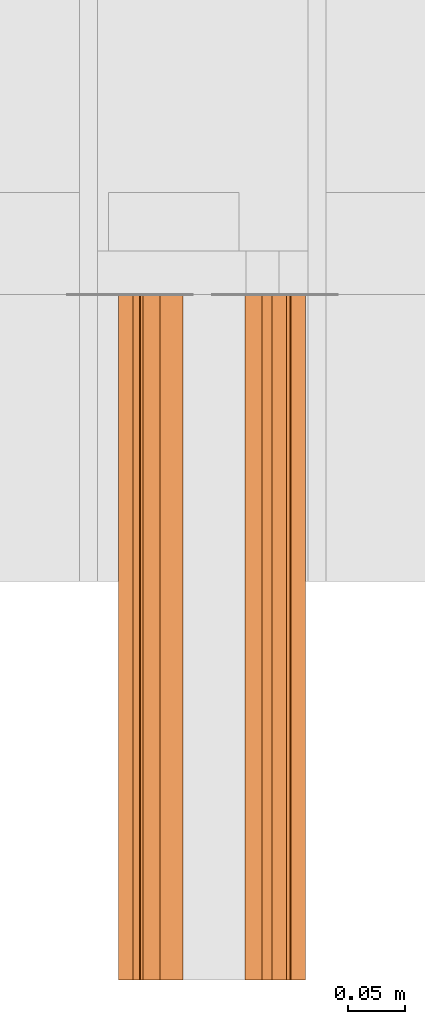
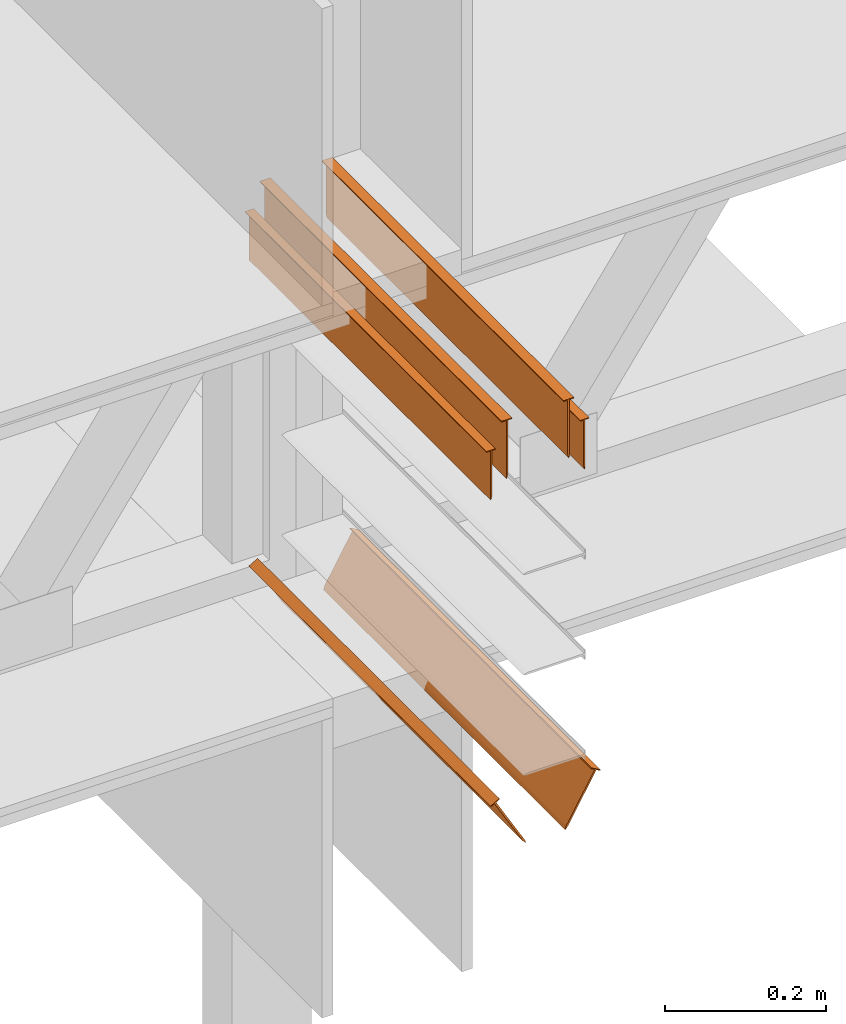
# One storey, part 2 of 2: 4 proxies.
"""IFC2X3 building model written with IfcOpenShell, lengths in metres."""

from ifc_helpers import new_model, si_unit, frame, frame_2d, origin_with_axes, place, context, subcontext, project, spatial, faceted_brep, element, save


model = new_model("IFC2X3")

# Units and contexts
model_context = context("Model", 3, precision=1e-05, world=origin_with_axes())
plan_context = context("Plan", 2, precision=1e-05, world=frame_2d((0.0, 0.0, 0.0), x_axis=(1.0, 0.0, 0.0)))
body_context = subcontext(model_context, "Body", "Model", "MODEL_VIEW")
ifc_project = project(units=[si_unit("AREAUNIT", "SQUARE_METRE"), si_unit("VOLUMEUNIT", "CUBIC_METRE"), si_unit("LENGTHUNIT", "METRE")], contexts=[model_context, plan_context])

# Site, building, storey
site_placement = place(None, origin_with_axes())
site = spatial("IfcSite", under=ifc_project, at=site_placement, CompositionType="ELEMENT")
building_placement = place(site_placement, origin_with_axes())
building = spatial("IfcBuilding", under=site, at=building_placement, Name="Building", CompositionType="ELEMENT")
storey_placement = place(building_placement, origin_with_axes())
storey = spatial("IfcBuildingStorey", under=building, at=storey_placement, Name="Storey", CompositionType="ELEMENT")

# Proxies
proxy_1_placement = place(storey_placement, frame((1.90271139144897, -0.162212371826172, 1.34063541889191), z_axis=(0.0, 0.0, 1.0), x_axis=(-1.62920684942947e-07, 1.0, 0.0)))
element("IfcBuildingElementProxy", 1, at=proxy_1_placement, inside=storey, Name="Generic Models 856:Generic Models 1:245", context=body_context, shape_type="Brep", body=[
    faceted_brep([(0.600274682044983, -0.00680737011134624, 0.00236264755949378), (0.600274682044983, -0.00744043942540884, 0.0), (0.0, -0.00744043942540884, 0.0), (0.0, -0.00680737011134624, 0.00236264755949378), (0.600274682044983, -0.0890476405620575, 0.0897103920578957), (0.600274682044983, -0.0890476405620575, 0.0883321240544319), (0.0, -0.0890476405620575, 0.0883321240544319), (0.0, -0.0890476405620575, 0.0897103920578957), (0.600274682044983, -0.00936781149357557, 0.00719304941594601), (0.600274682044983, -0.00936781149357557, 0.0883321240544319), (0.600274682044983, -0.0148808788508177, 0.0897103920578957), (0.600274682044983, -0.0148808788508177, 0.0883321240544319), (0.600274682044983, -0.00680737011134624, 0.0883321240544319), (0.600274682044983, 0.0, 0.0897103920578957), (0.600274682044983, 0.0, 0.0883321240544319), (0.0, 0.0, 0.0883321240544319), (0.0, 0.0, 0.0897103920578957), (0.600274682044983, -0.0945607125759125, 0.00719304941594601), (0.600274682044983, -0.0971211642026901, 0.00236264755949378), (0.600274682044983, -0.0964880883693695, 0.0), (0.600274682044983, -0.0971211642026901, 0.0883321240544319), (0.600274682044983, -0.103928528726101, 0.0897103920578957), (0.600274682044983, -0.103928528726101, 0.0883321240544319), (0.600274682044983, -0.0945607125759125, 0.0883321240544319), (0.0, -0.0148808788508177, 0.0883321240544319), (0.0, -0.00936781149357557, 0.0883321240544319), (0.0, -0.0945607125759125, 0.0883321240544319), (0.0, -0.0971211642026901, 0.0883321240544319), (0.0, -0.103928528726101, 0.0897103920578957), (0.0, -0.103928528726101, 0.0883321240544319), (0.0, -0.0945607125759125, 0.00719304941594601), (0.0, -0.0964880883693695, 0.0), (0.0, -0.0971211642026901, 0.00236264755949378), (0.0, -0.00680737011134624, 0.0883321240544319), (0.0, -0.0148808788508177, 0.0897103920578957), (0.0, -0.00936781149357557, 0.00719304941594601)], [[[0, 1, 2, 3]], [[4, 5, 6, 7]], [[8, 1, 0]], [[9, 10, 11]], [[12, 9, 8]], [[12, 10, 9]], [[13, 12, 14]], [[13, 10, 12]], [[0, 12, 8]], [[13, 14, 15, 16]], [[17, 18, 19]], [[20, 21, 22]], [[23, 20, 17]], [[4, 23, 5]], [[4, 21, 20]], [[4, 20, 23]], [[20, 18, 17]], [[9, 11, 24, 25]], [[26, 7, 6]], [[27, 7, 26]], [[28, 7, 27]], [[29, 28, 27]], [[30, 27, 26]], [[31, 32, 30]], [[32, 27, 30]], [[19, 18, 32, 31]], [[22, 29, 27, 20]], [[14, 12, 33, 15]], [[21, 4, 7, 28]], [[22, 21, 28, 29]], [[34, 10, 13, 16]], [[5, 23, 26, 6]], [[27, 32, 18, 20]], [[33, 16, 15]], [[34, 16, 33]], [[34, 33, 25]], [[24, 34, 25]], [[35, 25, 33]], [[2, 35, 3]], [[33, 3, 35]], [[8, 9, 25, 35]], [[12, 0, 3, 33]], [[23, 17, 30, 26]], [[1, 8, 35, 2]], [[17, 19, 31, 30]], [[11, 10, 34, 24]]]),
])
proxy_2_placement = place(storey_placement, frame((1.88110494613647, -0.162212371826172, 1.31583797931671), z_axis=(0.0, 0.0, 1.0), x_axis=(-1.62920684942947e-07, 1.0, 0.0)))
element("IfcBuildingElementProxy", 2, at=proxy_2_placement, inside=storey, Name="Generic Models 858:Generic Models 1:245", context=body_context, shape_type="Brep", body=[
    faceted_brep([(0.600274682044983, -0.00795701798051596, 0.00610977550968528), (0.600274682044983, -0.00631990935653448, 0.0), (0.600274682044983, -0.00578217953443527, 0.00200683274306357), (0.600274682044983, -0.00795701798051596, 0.0750292986631393), (0.600274682044983, -0.012639818713069, 0.0762000009417534), (0.600274682044983, -0.012639818713069, 0.0750292986631393), (0.600274682044983, -0.00578217953443527, 0.0750292986631393), (0.600274682044983, 0.0, 0.0762000009417534), (0.600274682044983, 0.0, 0.0750292986631393), (0.0, 0.0, 0.0750292986631393), (0.0, 0.0, 0.0762000009417534), (0.0, -0.00578217953443527, 0.0750292986631393), (0.0, -0.012639818713069, 0.0762000009417534), (0.0, -0.00795701798051596, 0.0750292986631393), (0.0, -0.012639818713069, 0.0750292986631393), (0.0, -0.00795701798051596, 0.00610977550968528), (0.0, -0.00631990935653448, 0.0), (0.0, -0.00578217953443527, 0.00200683274306357)], [[[0, 1, 2]], [[3, 4, 5]], [[6, 3, 0]], [[6, 4, 3]], [[7, 6, 8]], [[7, 4, 6]], [[2, 6, 0]], [[7, 8, 9, 10]], [[11, 10, 9]], [[12, 10, 11]], [[12, 11, 13]], [[14, 12, 13]], [[15, 13, 11]], [[16, 15, 17]], [[11, 17, 15]], [[2, 1, 16, 17]], [[6, 11, 9, 8]], [[4, 12, 14, 5]], [[0, 3, 13, 15]], [[6, 2, 17, 11]], [[1, 0, 15, 16]], [[12, 4, 7, 10]], [[3, 5, 14, 13]]]),
])
proxy_3_placement = place(storey_placement, frame((1.88681173324585, -0.162212371826172, 0.779132962226868), z_axis=(0.0, 0.0, 1.0), x_axis=(-1.62920684942947e-07, 1.0, 0.0)))
element("IfcBuildingElementProxy", 3, at=proxy_3_placement, inside=storey, Name="Generic Models 859:Generic Models 1:245", context=body_context, shape_type="Brep", body=[
    faceted_brep([(0.600274682044983, -0.0497896634042263, 0.00406986707821488), (0.600274682044983, -0.0508801750838757, 0.0), (0.600274682044983, -0.0466611683368683, 0.00421900907531381), (0.600274682044983, -0.00577571149915457, 0.0750346928834915), (0.600274682044983, -0.00068290822673589, 0.0720943659543991), (0.600274682044983, 0.0, 0.0732771977782249), (0.600274682044983, -0.151778236031532, 0.0752615705132484), (0.600274682044983, -0.110046081244946, 0.00297934957779944), (0.600274682044983, -0.10861099511385, 0.00576327368617058), (0.600274682044983, -0.149496451020241, 0.0765789672732353), (0.600274682044983, -0.00805750023573637, 0.0763520821928978), (0.600274682044983, -0.0128155779093504, 0.0806762725114822), (0.600274682044983, -0.013498486019671, 0.0794934406876564), (0.0, -0.151778236031532, 0.0752615705132484), (0.0, -0.110046081244946, 0.00297934957779944), (0.600274682044983, -0.157902136445045, 0.0733030438423157), (0.600274682044983, -0.14508655667305, 0.0807021260261536), (0.0, -0.14508655667305, 0.0807021260261536), (0.0, -0.157902136445045, 0.0733030438423157), (0.0, -0.0128155779093504, 0.0806762725114822), (0.0, -0.013498486019671, 0.0794934406876564), (0.600274682044983, -0.157219216227531, 0.0721202120184898), (0.0, -0.157219216227531, 0.0721202120184898), (0.0, -0.00577571149915457, 0.0750346928834915), (0.0, 0.0, 0.0732771977782249), (0.0, -0.00068290822673589, 0.0720943659543991), (0.0, -0.00805750023573637, 0.0763520821928978), (0.0, -0.0508801750838757, 0.0), (0.0, -0.0497896634042263, 0.00406986707821488), (0.0, -0.0466611683368683, 0.00421900907531381), (0.0, -0.149496451020241, 0.0765789672732353), (0.0, -0.144403651356697, 0.0795192867517471), (0.0, -0.10861099511385, 0.00576327368617058), (0.0, -0.107066728174686, 0.0), (0.600274682044983, -0.107066728174686, 0.0), (0.600274682044983, -0.144403651356697, 0.0795192867517471)], [[[0, 1, 2]], [[3, 4, 5]], [[6, 7, 8, 9]], [[10, 3, 5]], [[11, 12, 10]], [[11, 10, 5]], [[7, 6, 13, 14]], [[15, 16, 17, 18]], [[12, 11, 19, 20]], [[21, 15, 18, 22]], [[23, 24, 25]], [[26, 24, 23]], [[19, 24, 26]], [[20, 19, 26]], [[10, 0, 2, 3]], [[27, 28, 29]], [[30, 17, 31]], [[13, 17, 30]], [[18, 17, 13]], [[22, 18, 13]], [[14, 32, 33]], [[8, 34, 33, 32]], [[11, 5, 24, 19]], [[4, 3, 23, 25]], [[2, 1, 27, 29]], [[34, 7, 14, 33]], [[5, 4, 25, 24]], [[16, 35, 31, 17]], [[8, 7, 34]], [[9, 35, 16]], [[14, 13, 30, 32]], [[6, 9, 16]], [[15, 21, 6]], [[15, 6, 16]], [[0, 10, 26, 28]], [[6, 21, 22, 13]], [[9, 8, 32, 30]], [[28, 26, 23, 29]], [[1, 0, 28, 27]], [[3, 2, 29, 23]], [[10, 12, 20, 26]], [[35, 9, 30, 31]]]),
])
proxy_4_placement = place(storey_placement, frame((2.01559591293335, -0.162212371826172, 1.31583797931671), z_axis=(0.0, 0.0, 1.0), x_axis=(-1.62920684942947e-07, 1.0, 0.0)))
element("IfcBuildingElementProxy", 4, at=proxy_4_placement, inside=storey, Name="Generic Models 861:Generic Models 1:245", context=body_context, shape_type="Brep", body=[
    faceted_brep([(0.0, -0.00468279933556914, 0.0750292986631393), (0.0, 0.0, 0.0762000009417534), (0.0, 0.0, 0.0750292986631393), (0.0, -0.00685763824731112, 0.0750292986631393), (0.0, -0.012639818713069, 0.0762000009417534), (0.0, -0.012639818713069, 0.0750292986631393), (0.0, -0.00468279933556914, 0.00610977550968528), (0.0, -0.00631990935653448, 0.0), (0.0, -0.00685763824731112, 0.00200683274306357), (0.600274682044983, -0.00468279933556914, 0.00610977550968528), (0.600274682044983, -0.00685763824731112, 0.00200683274306357), (0.600274682044983, -0.00631990935653448, 0.0), (0.600274682044983, -0.00685763824731112, 0.0750292986631393), (0.600274682044983, -0.012639818713069, 0.0762000009417534), (0.600274682044983, -0.012639818713069, 0.0750292986631393), (0.600274682044983, -0.00468279933556914, 0.0750292986631393), (0.600274682044983, 0.0, 0.0762000009417534), (0.600274682044983, 0.0, 0.0750292986631393)], [[[0, 1, 2]], [[3, 1, 0]], [[4, 1, 3]], [[5, 4, 3]], [[6, 3, 0]], [[7, 8, 6]], [[8, 3, 6]], [[9, 10, 11]], [[12, 13, 14]], [[15, 12, 9]], [[16, 15, 17]], [[16, 13, 12]], [[16, 12, 15]], [[12, 10, 9]], [[9, 11, 7, 6]], [[16, 17, 2, 1]], [[13, 4, 5, 14]], [[15, 9, 6, 0]], [[15, 0, 2, 17]], [[11, 10, 8, 7]], [[3, 8, 10, 12]], [[14, 5, 3, 12]], [[4, 13, 16, 1]]]),
])

save(model, "model.ifc")
